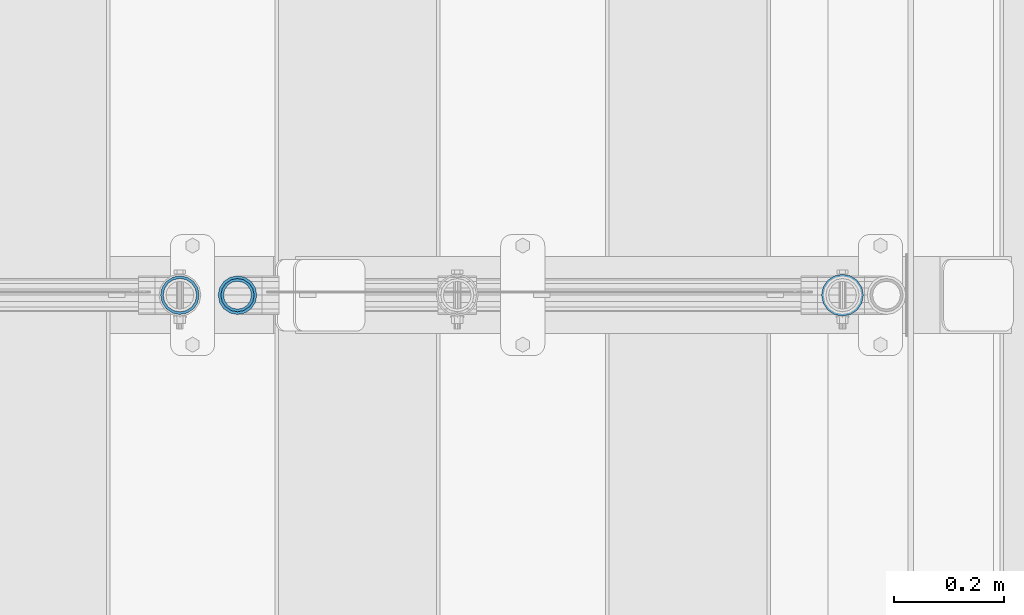
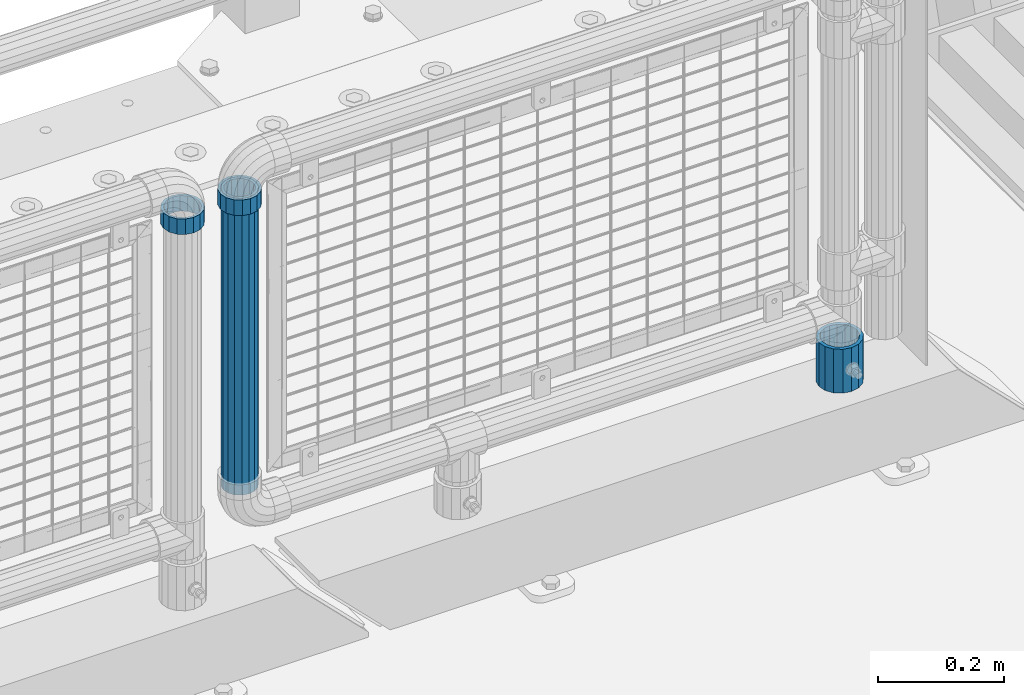
# One storey, part 82 of 193: 4 columns.
"""IFC2X3 building model written with IfcOpenShell, lengths in millimetres."""

from ifc_helpers import new_model, si_unit, frame, origin_with_axes, place, context, subcontext, project, spatial, faceted_brep, material, type_object, element, save


model = new_model("IFC2X3")

# Units and contexts
model_context = context("Model", 3, precision=1e-05, world=origin_with_axes())
body_context = subcontext(model_context, "Body", "Model", "MODEL_VIEW")
ifc_project = project(units=[si_unit("LENGTHUNIT", "METRE", prefix="MILLI"), si_unit("AREAUNIT", "SQUARE_METRE"), si_unit("VOLUMEUNIT", "CUBIC_METRE"), si_unit("MASSUNIT", "GRAM", prefix="KILO"), si_unit("TIMEUNIT", "SECOND"), si_unit("PLANEANGLEUNIT", "RADIAN"), si_unit("SOLIDANGLEUNIT", "STERADIAN"), si_unit("THERMODYNAMICTEMPERATUREUNIT", "DEGREE_CELSIUS"), si_unit("LUMINOUSINTENSITYUNIT", "LUMEN")], contexts=[model_context])

# Site, building, storey
site_placement = place(None, origin_with_axes())
site = spatial("IfcSite", under=ifc_project, at=site_placement, CompositionType="ELEMENT")
building_placement = place(site_placement, origin_with_axes())
building = spatial("IfcBuilding", under=site, at=building_placement, Name="Standard", CompositionType="ELEMENT")
storey_placement = place(building_placement, origin_with_axes())
storey = spatial("IfcBuildingStorey", under=building, at=storey_placement, Name="Undefined", CompositionType="ELEMENT", Elevation=0.0)

# Columns
ifc_material_1 = material(Name="Misc_Undefined")
column_type_1 = type_object("IfcColumnType", PredefinedType="NOTDEFINED")
column_1_placement = place(storey_placement, frame((-30223.0, 28664.5, 894.85), z_axis=(1.0, 0.0, 0.0), x_axis=(0.0, 0.0, 1.0)))
element("IfcColumn", 1, at=column_1_placement, inside=storey, type_object=column_type_1, material=ifc_material_1, context=body_context, shape_type="Brep", body=[
    faceted_brep([(0.0, -30.3499999999985, 0.0), (0.0, -28.0397438117179, 11.614442172282), (30.0, -28.0397438117179, 11.6144421722805), (30.0, -30.3499999999985, 0.0), (0.0, -21.46069080901, 21.46069080901), (30.0, -21.46069080901, 21.4606908090117), (0.0, -11.614442172282, 28.0397438117179), (30.0, -11.614442172282, 28.0397438117176), (0.0, 0.0, 30.3499999999985), (30.0, 0.0, 30.35), (0.0, 11.614442172282, 28.0397438117179), (30.0, 11.614442172282, 28.0397438117176), (0.0, 21.46069080901, 21.46069080901), (30.0, 21.46069080901, 21.4606908090117), (0.0, 28.0397438117179, 11.614442172282), (30.0, 28.0397438117179, 11.6144421722805), (0.0, 30.3499999999985, 0.0), (30.0, 30.3499999999985, 0.0), (0.0, 28.0397438117179, -11.614442172282), (30.0, 28.0397438117179, -11.6144421722805), (0.0, 21.46069080901, -21.46069080901), (30.0, 21.46069080901, -21.4606908090117), (0.0, 11.614442172282, -28.0397438117179), (30.0, 11.614442172282, -28.0397438117176), (0.0, 0.0, -30.3499999999985), (30.0, 0.0, -30.35), (0.0, -11.614442172282, -28.0397438117179), (30.0, -11.614442172282, -28.0397438117176), (0.0, -21.46069080901, -21.46069080901), (30.0, -21.46069080901, -21.4606908090117), (0.0, -28.0397438117179, -11.614442172282), (30.0, -28.0397438117179, -11.6144421722805), (0.0, -35.1500000000015, 0.0), (0.0, -32.4743655677703, -13.4513226476338), (30.0, -32.4743655677703, -13.4513226476329), (30.0, -35.1500000000015, 0.0), (0.0, -24.8548033587067, -24.8548033587067), (30.0, -24.8548033587067, -24.8548033587072), (0.0, -13.4513226476338, -32.4743655677703), (30.0, -13.4513226476338, -32.4743655677718), (0.0, 0.0, -35.1500000000015), (30.0, 0.0, -35.15), (0.0, 13.4513226476338, -32.4743655677703), (30.0, 13.4513226476338, -32.4743655677718), (0.0, 24.8548033587067, -24.8548033587067), (30.0, 24.8548033587067, -24.8548033587072), (0.0, 32.4743655677703, -13.4513226476338), (30.0, 32.4743655677703, -13.4513226476329), (0.0, 35.1500000000015, 0.0), (30.0, 35.1500000000015, 0.0), (0.0, 32.4743655677703, 13.4513226476338), (30.0, 32.4743655677703, 13.4513226476329), (0.0, 24.8548033587067, 24.8548033587067), (30.0, 24.8548033587067, 24.8548033587072), (0.0, 13.4513226476338, 32.4743655677703), (30.0, 13.4513226476338, 32.4743655677718), (0.0, 0.0, 35.1500000000015), (30.0, 0.0, 35.15), (0.0, -13.4513226476338, 32.4743655677703), (30.0, -13.4513226476338, 32.4743655677718), (0.0, -24.8548033587067, 24.8548033587067), (30.0, -24.8548033587067, 24.8548033587072), (0.0, -32.4743655677703, 13.4513226476338), (30.0, -32.4743655677703, 13.4513226476329)], [[[0, 1, 2, 3]], [[1, 4, 5, 2]], [[4, 6, 7, 5]], [[6, 8, 9, 7]], [[8, 10, 11, 9]], [[10, 12, 13, 11]], [[12, 14, 15, 13]], [[14, 16, 17, 15]], [[16, 18, 19, 17]], [[18, 20, 21, 19]], [[20, 22, 23, 21]], [[22, 24, 25, 23]], [[24, 26, 27, 25]], [[26, 28, 29, 27]], [[28, 30, 31, 29]], [[30, 0, 3, 31]], [[32, 33, 34, 35]], [[33, 36, 37, 34]], [[36, 38, 39, 37]], [[38, 40, 41, 39]], [[40, 42, 43, 41]], [[42, 44, 45, 43]], [[44, 46, 47, 45]], [[46, 48, 49, 47]], [[48, 50, 51, 49]], [[50, 52, 53, 51]], [[52, 54, 55, 53]], [[54, 56, 57, 55]], [[56, 58, 59, 57]], [[58, 60, 61, 59]], [[60, 62, 63, 61]], [[62, 32, 35, 63]], [[37, 39, 41, 43, 45, 47, 49, 51, 53, 55, 57, 59, 61, 63, 35, 34], [5, 7, 9, 11, 13, 15, 17, 19, 21, 23, 25, 27, 29, 31, 3, 2]], [[62, 60, 58, 56, 54, 52, 50, 48, 46, 44, 42, 40, 38, 36, 33, 32], [30, 28, 26, 24, 22, 20, 18, 16, 14, 12, 10, 8, 6, 4, 1, 0]]]),
])
column_2_placement = place(storey_placement, frame((-30118.39, 28664.5, 894.849999999999), z_axis=(-1.0, 0.0, 0.0), x_axis=(0.0, 0.0, 1.0)))
element("IfcColumn", 2, at=column_2_placement, inside=storey, type_object=column_type_1, material=ifc_material_1, context=body_context, shape_type="Brep", body=[
    faceted_brep([(0.0, -30.3499999999985, 0.0), (0.0, -28.0397438117179, 11.614442172282), (30.0, -28.0397438117179, 11.6144421722805), (30.0, -30.3499999999985, 0.0), (0.0, -21.46069080901, 21.46069080901), (30.0, -21.46069080901, 21.4606908090117), (0.0, -11.614442172282, 28.0397438117179), (30.0, -11.614442172282, 28.0397438117176), (0.0, 0.0, 30.3499999999985), (30.0, 0.0, 30.35), (0.0, 11.614442172282, 28.0397438117179), (30.0, 11.614442172282, 28.0397438117176), (0.0, 21.46069080901, 21.46069080901), (30.0, 21.46069080901, 21.4606908090117), (0.0, 28.0397438117179, 11.614442172282), (30.0, 28.0397438117179, 11.6144421722805), (0.0, 30.3499999999985, 0.0), (30.0, 30.3499999999985, 0.0), (0.0, 28.0397438117179, -11.614442172282), (30.0, 28.0397438117179, -11.6144421722805), (0.0, 21.46069080901, -21.46069080901), (30.0, 21.46069080901, -21.4606908090117), (0.0, 11.614442172282, -28.0397438117179), (30.0, 11.614442172282, -28.0397438117176), (0.0, 0.0, -30.3499999999985), (30.0, 0.0, -30.35), (0.0, -11.614442172282, -28.0397438117179), (30.0, -11.614442172282, -28.0397438117176), (0.0, -21.46069080901, -21.46069080901), (30.0, -21.46069080901, -21.4606908090117), (0.0, -28.0397438117179, -11.614442172282), (30.0, -28.0397438117179, -11.6144421722805), (0.0, -35.1500000000015, 0.0), (0.0, -32.4743655677703, -13.4513226476338), (30.0, -32.4743655677703, -13.4513226476329), (30.0, -35.1500000000015, 0.0), (0.0, -24.8548033587067, -24.8548033587067), (30.0, -24.8548033587067, -24.8548033587072), (0.0, -13.4513226476338, -32.4743655677703), (30.0, -13.4513226476338, -32.4743655677718), (0.0, 0.0, -35.1500000000015), (30.0, 0.0, -35.15), (0.0, 13.4513226476338, -32.4743655677703), (30.0, 13.4513226476338, -32.4743655677718), (0.0, 24.8548033587067, -24.8548033587067), (30.0, 24.8548033587067, -24.8548033587072), (0.0, 32.4743655677703, -13.4513226476338), (30.0, 32.4743655677703, -13.4513226476329), (0.0, 35.1500000000015, 0.0), (30.0, 35.1500000000015, 0.0), (0.0, 32.4743655677703, 13.4513226476338), (30.0, 32.4743655677703, 13.4513226476329), (0.0, 24.8548033587067, 24.8548033587067), (30.0, 24.8548033587067, 24.8548033587072), (0.0, 13.4513226476338, 32.4743655677703), (30.0, 13.4513226476338, 32.4743655677718), (0.0, 0.0, 35.1500000000015), (30.0, 0.0, 35.15), (0.0, -13.4513226476338, 32.4743655677703), (30.0, -13.4513226476338, 32.4743655677718), (0.0, -24.8548033587067, 24.8548033587067), (30.0, -24.8548033587067, 24.8548033587072), (0.0, -32.4743655677703, 13.4513226476338), (30.0, -32.4743655677703, 13.4513226476329)], [[[0, 1, 2, 3]], [[1, 4, 5, 2]], [[4, 6, 7, 5]], [[6, 8, 9, 7]], [[8, 10, 11, 9]], [[10, 12, 13, 11]], [[12, 14, 15, 13]], [[14, 16, 17, 15]], [[16, 18, 19, 17]], [[18, 20, 21, 19]], [[20, 22, 23, 21]], [[22, 24, 25, 23]], [[24, 26, 27, 25]], [[26, 28, 29, 27]], [[28, 30, 31, 29]], [[30, 0, 3, 31]], [[32, 33, 34, 35]], [[33, 36, 37, 34]], [[36, 38, 39, 37]], [[38, 40, 41, 39]], [[40, 42, 43, 41]], [[42, 44, 45, 43]], [[44, 46, 47, 45]], [[46, 48, 49, 47]], [[48, 50, 51, 49]], [[50, 52, 53, 51]], [[52, 54, 55, 53]], [[54, 56, 57, 55]], [[56, 58, 59, 57]], [[58, 60, 61, 59]], [[60, 62, 63, 61]], [[62, 32, 35, 63]], [[37, 39, 41, 43, 45, 47, 49, 51, 53, 55, 57, 59, 61, 63, 35, 34], [5, 7, 9, 11, 13, 15, 17, 19, 21, 23, 25, 27, 29, 31, 3, 2]], [[62, 60, 58, 56, 54, 52, 50, 48, 46, 44, 42, 40, 38, 36, 33, 32], [30, 28, 26, 24, 22, 20, 18, 16, 14, 12, 10, 8, 6, 4, 1, 0]]]),
])
ifc_material_2 = material()
column_type_2 = type_object("IfcColumnType", PredefinedType="NOTDEFINED")
column_3_placement = place(storey_placement, frame((-30118.39, 28664.5, 349.86), z_axis=(-1.0, 0.0, 0.0), x_axis=(0.0, 0.0, 1.0)))
element("IfcColumn", 3, at=column_3_placement, inside=storey, type_object=column_type_2, material=ifc_material_2, context=body_context, shape_type="Brep", body=[
    faceted_brep([(0.0, -25.3499999999985, 0.0), (0.0, -23.4203461491597, 9.70102501045403), (574.992910334213, -23.4203461491597, 9.70102501045403), (574.990000024649, -25.3499999999985, 0.0), (0.0, -17.9251569030785, 17.9251569030785), (574.995377579387, -17.9251569030785, 17.9251569030785), (0.0, -9.70102501045403, 23.4203461491597), (574.997026144459, -9.70102501045403, 23.4203461491597), (0.0, 0.0, 25.3499999999985), (574.997605050341, 0.0, 25.3499999999985), (0.0, 9.70102501045403, 23.4203461491597), (574.997026163861, 9.70102501045403, 23.4203461491597), (0.0, 17.9251569030785, 17.9251569030785), (574.995377615237, 17.9251569030785, 17.9251569030785), (0.0, 23.4203461491597, 9.70102501045403), (574.992910381054, 23.4203461491597, 9.70102501045403), (0.0, 25.3499999999985, 0.0), (574.990000075349, 25.3499999999985, 0.0), (0.0, 23.4203461491597, -9.70102501045403), (574.987089765785, 23.4203461491597, -9.70102501045403), (0.0, 17.9251569030785, -17.9251569030785), (574.984622520612, 17.9251569030785, -17.9251569030785), (0.0, 9.70102501045403, -23.4203461491597), (574.982973955539, 9.70102501045403, -23.4203461491597), (0.0, 0.0, -25.3499999999985), (574.982395049657, 0.0, -25.3499999999985), (0.0, -9.70102501045403, -23.4203461491597), (574.982973936137, -9.70102501045403, -23.4203461491597), (0.0, -17.9251569030785, -17.9251569030785), (574.984622484761, -17.9251569030785, -17.9251569030785), (0.0, -23.4203461491597, -9.70102501045403), (574.987089718945, -23.4203461491597, -9.70102501045403), (0.0, -30.1500000000015, 0.0), (0.0, -27.8549679052157, -11.5379054858058), (574.986538650343, -27.8549679052157, -11.5379054858058), (574.990000019849, -30.1500000000015, 0.0), (0.0, -21.3192694527752, -21.3192694527752), (574.983604247556, -21.3192694527752, -21.3192694527752), (0.0, -11.5379054858058, -27.8549679052157), (574.981643547714, -11.5379054858058, -27.8549679052157), (0.0, 0.0, -30.1500000000015), (574.980955049592, 0.0, -30.1500000000015), (0.0, 11.5379054858058, -27.8549679052157), (574.98164357079, 11.5379054858058, -27.8549679052157), (0.0, 21.3192694527752, -21.3192694527752), (574.983604290195, 21.3192694527752, -21.3192694527752), (0.0, 27.8549679052157, -11.5379054858058), (574.986538706053, 27.8549679052157, -11.5379054858058), (0.0, 30.1500000000015, 0.0), (574.990000080149, 30.1500000000015, 0.0), (0.0, 27.8549679052157, 11.5379054858058), (574.993461449656, 27.8549679052157, 11.5379054858058), (0.0, 21.3192694527752, 21.3192694527752), (574.996395852442, 21.3192694527752, 21.3192694527752), (0.0, 11.5379054858058, 27.8549679052157), (574.998356552285, 11.5379054858058, 27.8549679052157), (0.0, 0.0, 30.1500000000015), (574.999045050406, 0.0, 30.1500000000015), (0.0, -11.5379054858058, 27.8549679052157), (574.998356529209, -11.5379054858058, 27.8549679052157), (0.0, -21.3192694527752, 21.3192694527752), (574.996395809804, -21.3192694527752, 21.3192694527752), (0.0, -27.8549679052157, 11.5379054858058), (574.993461393946, -27.8549679052157, 11.5379054858058)], [[[0, 1, 2, 3]], [[1, 4, 5, 2]], [[4, 6, 7, 5]], [[6, 8, 9, 7]], [[8, 10, 11, 9]], [[10, 12, 13, 11]], [[12, 14, 15, 13]], [[14, 16, 17, 15]], [[16, 18, 19, 17]], [[18, 20, 21, 19]], [[20, 22, 23, 21]], [[22, 24, 25, 23]], [[24, 26, 27, 25]], [[26, 28, 29, 27]], [[28, 30, 31, 29]], [[30, 0, 3, 31]], [[32, 33, 34, 35]], [[33, 36, 37, 34]], [[36, 38, 39, 37]], [[38, 40, 41, 39]], [[40, 42, 43, 41]], [[42, 44, 45, 43]], [[44, 46, 47, 45]], [[46, 48, 49, 47]], [[48, 50, 51, 49]], [[50, 52, 53, 51]], [[52, 54, 55, 53]], [[54, 56, 57, 55]], [[56, 58, 59, 57]], [[58, 60, 61, 59]], [[60, 62, 63, 61]], [[62, 32, 35, 63]], [[37, 39, 41, 43, 45, 47, 49, 51, 53, 55, 57, 59, 61, 63, 35, 34], [5, 7, 9, 11, 13, 15, 17, 19, 21, 23, 25, 27, 29, 31, 3, 2]], [[62, 60, 58, 56, 54, 52, 50, 48, 46, 44, 42, 40, 38, 36, 33, 32], [30, 28, 26, 24, 22, 20, 18, 16, 14, 12, 10, 8, 6, 4, 1, 0]]]),
])
column_type_3 = type_object("IfcColumnType", PredefinedType="NOTDEFINED")
column_4_placement = place(storey_placement, frame((-29019.0, 28664.5, 168.019999999998), z_axis=(0.0, 1.0, 0.0), x_axis=(0.0, 0.0, 1.0)))
element("IfcColumn", 4, at=column_4_placement, inside=storey, type_object=column_type_3, material=ifc_material_2, context=body_context, shape_type="Brep", body=[
    faceted_brep([(0.0, -31.75, 0.0), (0.0, -29.3331751572332, 12.1501989775934), (85.0, -29.3331751572332, 12.1501989775934), (85.0, -31.75, 0.0), (0.0, -22.4506403026717, 22.4506403026717), (85.0, -22.4506403026717, 22.4506403026717), (0.0, -12.1501989775934, 29.3331751572332), (85.0, -12.1501989775934, 29.3331751572332), (0.0, 0.0, 31.75), (85.0, 0.0, 31.75), (0.0, 12.1501989775934, 29.3331751572332), (85.0, 12.1501989775934, 29.3331751572332), (0.0, 22.4506403026717, 22.4506403026717), (85.0, 22.4506403026717, 22.4506403026717), (0.0, 29.3331751572332, 12.1501989775934), (85.0, 29.3331751572332, 12.1501989775934), (0.0, 31.75, 0.0), (85.0, 31.75, 0.0), (0.0, 29.3331751572332, -12.1501989775934), (85.0, 29.3331751572332, -12.1501989775934), (0.0, 22.4506403026717, -22.4506403026717), (85.0, 22.4506403026717, -22.4506403026717), (0.0, 12.1501989775934, -29.3331751572332), (85.0, 12.1501989775934, -29.3331751572332), (0.0, 0.0, -31.75), (85.0, 0.0, -31.75), (0.0, -12.1501989775934, -29.3331751572332), (85.0, -12.1501989775934, -29.3331751572332), (0.0, -22.4506403026717, -22.4506403026717), (85.0, -22.4506403026717, -22.4506403026717), (0.0, -29.3331751572332, -12.1501989775934), (85.0, -29.3331751572332, -12.1501989775934), (0.0, -38.0499999999993, 0.0), (0.0, -35.1536162120537, -14.5611046014928), (85.0, -35.1536162120537, -14.5611046014928), (85.0, -38.0499999999993, 0.0), (0.0, -26.9054130241493, -26.9054130241493), (85.0, -26.9054130241493, -26.9054130241493), (0.0, -14.5611046014928, -35.1536162120537), (85.0, -14.5611046014928, -35.1536162120537), (0.0, 0.0, -38.0499999999993), (85.0, 0.0, -38.0499999999993), (0.0, 14.5611046014928, -35.1536162120537), (85.0, 14.5611046014928, -35.1536162120537), (0.0, 26.9054130241493, -26.9054130241493), (85.0, 26.9054130241493, -26.9054130241493), (0.0, 35.1536162120537, -14.5611046014928), (85.0, 35.1536162120537, -14.5611046014928), (0.0, 38.0499999999993, 0.0), (85.0, 38.0499999999993, 0.0), (0.0, 35.1536162120537, 14.5611046014928), (85.0, 35.1536162120537, 14.5611046014928), (0.0, 26.9054130241493, 26.9054130241493), (85.0, 26.9054130241493, 26.9054130241493), (0.0, 14.5611046014928, 35.1536162120537), (85.0, 14.5611046014928, 35.1536162120537), (0.0, 0.0, 38.0499999999993), (85.0, 0.0, 38.0499999999993), (0.0, -14.5611046014928, 35.1536162120537), (85.0, -14.5611046014928, 35.1536162120537), (0.0, -26.9054130241493, 26.9054130241493), (85.0, -26.9054130241493, 26.9054130241493), (0.0, -35.1536162120537, 14.5611046014928), (85.0, -35.1536162120537, 14.5611046014928)], [[[0, 1, 2, 3]], [[1, 4, 5, 2]], [[4, 6, 7, 5]], [[6, 8, 9, 7]], [[8, 10, 11, 9]], [[10, 12, 13, 11]], [[12, 14, 15, 13]], [[14, 16, 17, 15]], [[16, 18, 19, 17]], [[18, 20, 21, 19]], [[20, 22, 23, 21]], [[22, 24, 25, 23]], [[24, 26, 27, 25]], [[26, 28, 29, 27]], [[28, 30, 31, 29]], [[30, 0, 3, 31]], [[32, 33, 34, 35]], [[33, 36, 37, 34]], [[36, 38, 39, 37]], [[38, 40, 41, 39]], [[40, 42, 43, 41]], [[42, 44, 45, 43]], [[44, 46, 47, 45]], [[46, 48, 49, 47]], [[48, 50, 51, 49]], [[50, 52, 53, 51]], [[52, 54, 55, 53]], [[54, 56, 57, 55]], [[56, 58, 59, 57]], [[58, 60, 61, 59]], [[60, 62, 63, 61]], [[62, 32, 35, 63]], [[37, 39, 41, 43, 45, 47, 49, 51, 53, 55, 57, 59, 61, 63, 35, 34], [5, 7, 9, 11, 13, 15, 17, 19, 21, 23, 25, 27, 29, 31, 3, 2]], [[62, 60, 58, 56, 54, 52, 50, 48, 46, 44, 42, 40, 38, 36, 33, 32], [30, 28, 26, 24, 22, 20, 18, 16, 14, 12, 10, 8, 6, 4, 1, 0]]]),
])

save(model, "model.ifc")
